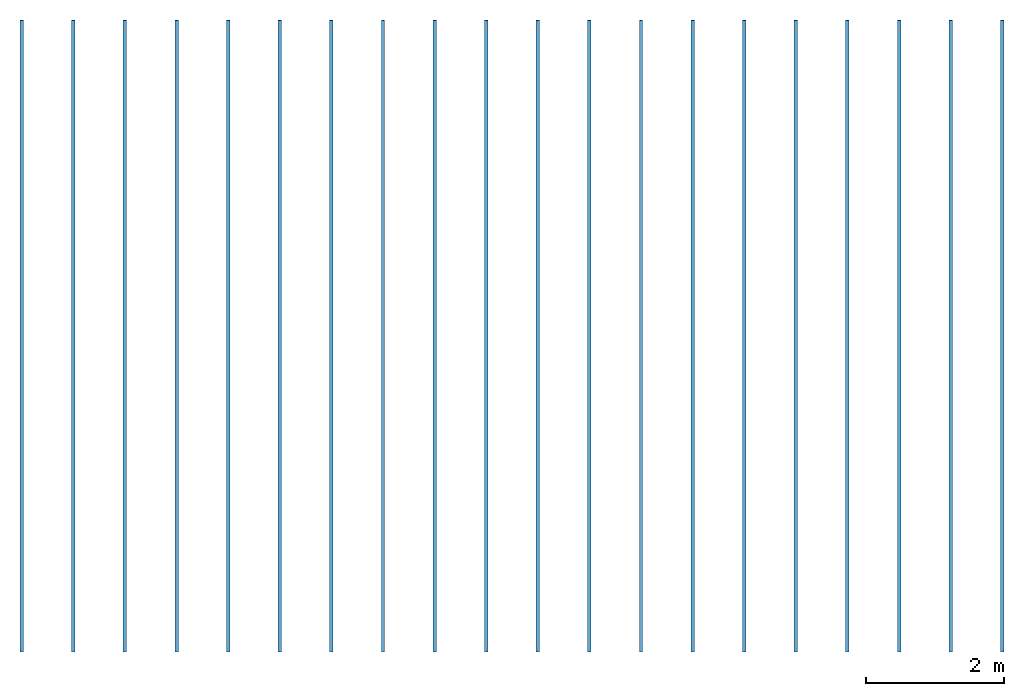
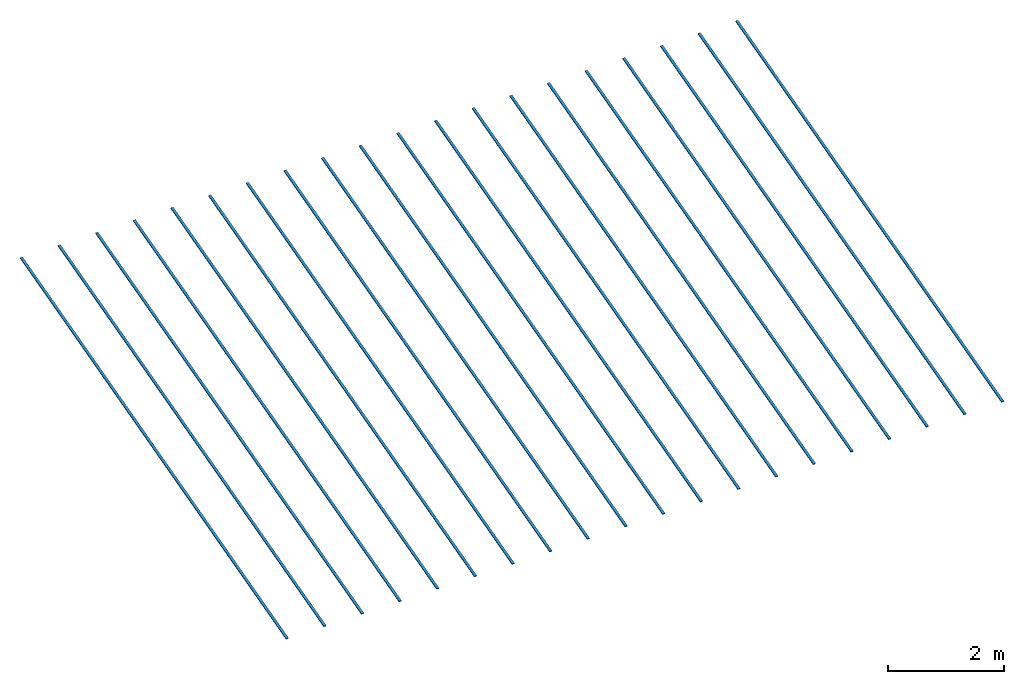
# Not in any storey: 20 beams.
"""IFC4 model written with IfcOpenShell, lengths in metres."""

from ifc_helpers import new_model, entity, si_unit, converted_unit, frame, origin_with_axes, origin_2d_with_axis, place, context, subcontext, project, rectangle, extrude, material, material_profile, profile_set, profile_usage, type_object, element, save


model = new_model("IFC4")

# Units and contexts
model_context = context("Model", 3, precision=1e-05, world=origin_with_axes())
plan_context = context("Plan", 2, precision=1e-05, world=origin_2d_with_axis())
body_context = subcontext(model_context, "Body", "Model", "MODEL_VIEW")
ifc_project = project(units=[si_unit("VOLUMEUNIT", "CUBIC_METRE"), si_unit("LENGTHUNIT", "METRE"), converted_unit("PLANEANGLEUNIT", "degree", entity("IfcReal", 0.0174532925199433), si_unit("PLANEANGLEUNIT", "RADIAN"), dimensions=[0, 0, 0, 0, 0, 0, 0]), si_unit("AREAUNIT", "SQUARE_METRE")], contexts=[model_context, plan_context])

# Beams
ifc_material = material()
ifc_material_profile = material_profile(ifc_material, rectangle(XDim=0.0500000007450581, YDim=0.0199999995529652))
ifc_profile_set = profile_set([ifc_material_profile])
ifc_profile_usage_1 = profile_usage(ifc_profile_set, cardinal=2)
beam_type = type_object("IfcBeamType", PredefinedType="BEAM", material=ifc_profile_set)
beam_1_placement = place(None, frame((-0.685000061988831, -1.53888702392578, 3.95000076293945), z_axis=(-1.05647404780029e-06, 0.965925574302673, 0.258819997310638), x_axis=(-1.0, -1.10467010472348e-06, 4.078152215925e-08)))
element("IfcBeam", 1, at=beam_1_placement, type_object=beam_type, material=ifc_profile_usage_1, Name="Beam", PredefinedType="NOTDEFINED", context=body_context, shape_type="SweptSolid", body=[
    extrude(rectangle(XDim=0.0500000007450581, YDim=0.0199999995529652), frame((0.0, 0.0099999997764826, 0.0), z_axis=(0.0, 0.0, 1.0), x_axis=(1.0, 0.0, 0.0)), (0.0, 0.0, 1.0), 9.49992295284267),
])
ifc_profile_usage_2 = profile_usage(ifc_profile_set, cardinal=2)
beam_2_placement = place(None, frame((0.0649999380111694, -1.53888702392578, 3.95000076293945), z_axis=(-1.05647404780029e-06, 0.965925574302673, 0.258819997310638), x_axis=(-1.0, -1.10467010472348e-06, 4.078152215925e-08)))
element("IfcBeam", 2, at=beam_2_placement, type_object=beam_type, material=ifc_profile_usage_2, Name="Beam", PredefinedType="NOTDEFINED", context=body_context, shape_type="SweptSolid", body=[
    extrude(rectangle(XDim=0.0500000007450581, YDim=0.0199999995529652), frame((0.0, 0.0099999997764826, 0.0), z_axis=(0.0, 0.0, 1.0), x_axis=(1.0, 0.0, 0.0)), (0.0, 0.0, 1.0), 9.49992295284267),
])
ifc_profile_usage_3 = profile_usage(ifc_profile_set, cardinal=2)
beam_3_placement = place(None, frame((0.814999938011169, -1.53888702392578, 3.95000076293945), z_axis=(-1.05647404780029e-06, 0.965925574302673, 0.258819997310638), x_axis=(-1.0, -1.10467010472348e-06, 4.078152215925e-08)))
element("IfcBeam", 3, at=beam_3_placement, type_object=beam_type, material=ifc_profile_usage_3, Name="Beam", PredefinedType="NOTDEFINED", context=body_context, shape_type="SweptSolid", body=[
    extrude(rectangle(XDim=0.0500000007450581, YDim=0.0199999995529652), frame((0.0, 0.0099999997764826, 0.0), z_axis=(0.0, 0.0, 1.0), x_axis=(1.0, 0.0, 0.0)), (0.0, 0.0, 1.0), 9.49992295284267),
])
ifc_profile_usage_4 = profile_usage(ifc_profile_set, cardinal=2)
beam_4_placement = place(None, frame((1.56499993801117, -1.53888702392578, 3.95000076293945), z_axis=(-1.05647404780029e-06, 0.965925574302673, 0.258819997310638), x_axis=(-1.0, -1.10467010472348e-06, 4.078152215925e-08)))
element("IfcBeam", 4, at=beam_4_placement, type_object=beam_type, material=ifc_profile_usage_4, Name="Beam", PredefinedType="NOTDEFINED", context=body_context, shape_type="SweptSolid", body=[
    extrude(rectangle(XDim=0.0500000007450581, YDim=0.0199999995529652), frame((0.0, 0.0099999997764826, 0.0), z_axis=(0.0, 0.0, 1.0), x_axis=(1.0, 0.0, 0.0)), (0.0, 0.0, 1.0), 9.49992295284267),
])
ifc_profile_usage_5 = profile_usage(ifc_profile_set, cardinal=2)
beam_5_placement = place(None, frame((2.31500005722046, -1.53888702392578, 3.95000076293945), z_axis=(-1.05647404780029e-06, 0.965925574302673, 0.258819997310638), x_axis=(-1.0, -1.10467010472348e-06, 4.078152215925e-08)))
element("IfcBeam", 5, at=beam_5_placement, type_object=beam_type, material=ifc_profile_usage_5, Name="Beam", PredefinedType="NOTDEFINED", context=body_context, shape_type="SweptSolid", body=[
    extrude(rectangle(XDim=0.0500000007450581, YDim=0.0199999995529652), frame((0.0, 0.0099999997764826, 0.0), z_axis=(0.0, 0.0, 1.0), x_axis=(1.0, 0.0, 0.0)), (0.0, 0.0, 1.0), 9.49992295284267),
])
ifc_profile_usage_6 = profile_usage(ifc_profile_set, cardinal=2)
beam_6_placement = place(None, frame((3.06500005722046, -1.53888702392578, 3.95000076293945), z_axis=(-1.05647404780029e-06, 0.965925574302673, 0.258819997310638), x_axis=(-1.0, -1.10467010472348e-06, 4.078152215925e-08)))
element("IfcBeam", 6, at=beam_6_placement, type_object=beam_type, material=ifc_profile_usage_6, Name="Beam", PredefinedType="NOTDEFINED", context=body_context, shape_type="SweptSolid", body=[
    extrude(rectangle(XDim=0.0500000007450581, YDim=0.0199999995529652), frame((0.0, 0.0099999997764826, 0.0), z_axis=(0.0, 0.0, 1.0), x_axis=(1.0, 0.0, 0.0)), (0.0, 0.0, 1.0), 9.49992295284267),
])
ifc_profile_usage_7 = profile_usage(ifc_profile_set, cardinal=2)
beam_7_placement = place(None, frame((3.81500005722046, -1.53888702392578, 3.95000076293945), z_axis=(-1.05647404780029e-06, 0.965925574302673, 0.258819997310638), x_axis=(-1.0, -1.10467010472348e-06, 4.078152215925e-08)))
element("IfcBeam", 7, at=beam_7_placement, type_object=beam_type, material=ifc_profile_usage_7, Name="Beam", PredefinedType="NOTDEFINED", context=body_context, shape_type="SweptSolid", body=[
    extrude(rectangle(XDim=0.0500000007450581, YDim=0.0199999995529652), frame((0.0, 0.0099999997764826, 0.0), z_axis=(0.0, 0.0, 1.0), x_axis=(1.0, 0.0, 0.0)), (0.0, 0.0, 1.0), 9.49992295284267),
])
ifc_profile_usage_8 = profile_usage(ifc_profile_set, cardinal=2)
beam_8_placement = place(None, frame((4.56500005722046, -1.53888702392578, 3.95000076293945), z_axis=(-1.05647404780029e-06, 0.965925574302673, 0.258819997310638), x_axis=(-1.0, -1.10467010472348e-06, 4.078152215925e-08)))
element("IfcBeam", 8, at=beam_8_placement, type_object=beam_type, material=ifc_profile_usage_8, Name="Beam", PredefinedType="NOTDEFINED", context=body_context, shape_type="SweptSolid", body=[
    extrude(rectangle(XDim=0.0500000007450581, YDim=0.0199999995529652), frame((0.0, 0.0099999997764826, 0.0), z_axis=(0.0, 0.0, 1.0), x_axis=(1.0, 0.0, 0.0)), (0.0, 0.0, 1.0), 9.49992295284267),
])
ifc_profile_usage_9 = profile_usage(ifc_profile_set, cardinal=2)
beam_9_placement = place(None, frame((5.31500005722046, -1.53888702392578, 3.95000076293945), z_axis=(-1.05647404780029e-06, 0.965925574302673, 0.258819997310638), x_axis=(-1.0, -1.10467010472348e-06, 4.078152215925e-08)))
element("IfcBeam", 9, at=beam_9_placement, type_object=beam_type, material=ifc_profile_usage_9, Name="Beam", PredefinedType="NOTDEFINED", context=body_context, shape_type="SweptSolid", body=[
    extrude(rectangle(XDim=0.0500000007450581, YDim=0.0199999995529652), frame((0.0, 0.0099999997764826, 0.0), z_axis=(0.0, 0.0, 1.0), x_axis=(1.0, 0.0, 0.0)), (0.0, 0.0, 1.0), 9.49992295284267),
])
ifc_profile_usage_10 = profile_usage(ifc_profile_set, cardinal=2)
beam_10_placement = place(None, frame((6.06500005722046, -1.53888702392578, 3.95000076293945), z_axis=(-1.05647404780029e-06, 0.965925574302673, 0.258819997310638), x_axis=(-1.0, -1.10467010472348e-06, 4.078152215925e-08)))
element("IfcBeam", 10, at=beam_10_placement, type_object=beam_type, material=ifc_profile_usage_10, Name="Beam", PredefinedType="NOTDEFINED", context=body_context, shape_type="SweptSolid", body=[
    extrude(rectangle(XDim=0.0500000007450581, YDim=0.0199999995529652), frame((0.0, 0.0099999997764826, 0.0), z_axis=(0.0, 0.0, 1.0), x_axis=(1.0, 0.0, 0.0)), (0.0, 0.0, 1.0), 9.49992295284267),
])
ifc_profile_usage_11 = profile_usage(ifc_profile_set, cardinal=2)
beam_11_placement = place(None, frame((6.81500005722046, -1.53888702392578, 3.95000076293945), z_axis=(-1.05647404780029e-06, 0.965925574302673, 0.258819997310638), x_axis=(-1.0, -1.10467010472348e-06, 4.078152215925e-08)))
element("IfcBeam", 11, at=beam_11_placement, type_object=beam_type, material=ifc_profile_usage_11, Name="Beam", PredefinedType="NOTDEFINED", context=body_context, shape_type="SweptSolid", body=[
    extrude(rectangle(XDim=0.0500000007450581, YDim=0.0199999995529652), frame((0.0, 0.0099999997764826, 0.0), z_axis=(0.0, 0.0, 1.0), x_axis=(1.0, 0.0, 0.0)), (0.0, 0.0, 1.0), 9.49992295284267),
])
ifc_profile_usage_12 = profile_usage(ifc_profile_set, cardinal=2)
beam_12_placement = place(None, frame((7.56500005722046, -1.53888702392578, 3.95000076293945), z_axis=(-1.05647404780029e-06, 0.965925574302673, 0.258819997310638), x_axis=(-1.0, -1.10467010472348e-06, 4.078152215925e-08)))
element("IfcBeam", 12, at=beam_12_placement, type_object=beam_type, material=ifc_profile_usage_12, Name="Beam", PredefinedType="NOTDEFINED", context=body_context, shape_type="SweptSolid", body=[
    extrude(rectangle(XDim=0.0500000007450581, YDim=0.0199999995529652), frame((0.0, 0.0099999997764826, 0.0), z_axis=(0.0, 0.0, 1.0), x_axis=(1.0, 0.0, 0.0)), (0.0, 0.0, 1.0), 9.49992295284267),
])
ifc_profile_usage_13 = profile_usage(ifc_profile_set, cardinal=2)
beam_13_placement = place(None, frame((8.3149995803833, -1.53888702392578, 3.95000076293945), z_axis=(-1.05647404780029e-06, 0.965925574302673, 0.258819997310638), x_axis=(-1.0, -1.10467010472348e-06, 4.078152215925e-08)))
element("IfcBeam", 13, at=beam_13_placement, type_object=beam_type, material=ifc_profile_usage_13, Name="Beam", PredefinedType="NOTDEFINED", context=body_context, shape_type="SweptSolid", body=[
    extrude(rectangle(XDim=0.0500000007450581, YDim=0.0199999995529652), frame((0.0, 0.0099999997764826, 0.0), z_axis=(0.0, 0.0, 1.0), x_axis=(1.0, 0.0, 0.0)), (0.0, 0.0, 1.0), 9.49992295284267),
])
ifc_profile_usage_14 = profile_usage(ifc_profile_set, cardinal=2)
beam_14_placement = place(None, frame((9.0649995803833, -1.53888702392578, 3.95000076293945), z_axis=(-1.05647404780029e-06, 0.965925574302673, 0.258819997310638), x_axis=(-1.0, -1.10467010472348e-06, 4.078152215925e-08)))
element("IfcBeam", 14, at=beam_14_placement, type_object=beam_type, material=ifc_profile_usage_14, Name="Beam", PredefinedType="NOTDEFINED", context=body_context, shape_type="SweptSolid", body=[
    extrude(rectangle(XDim=0.0500000007450581, YDim=0.0199999995529652), frame((0.0, 0.0099999997764826, 0.0), z_axis=(0.0, 0.0, 1.0), x_axis=(1.0, 0.0, 0.0)), (0.0, 0.0, 1.0), 9.49992295284267),
])
ifc_profile_usage_15 = profile_usage(ifc_profile_set, cardinal=2)
beam_15_placement = place(None, frame((9.8149995803833, -1.53888702392578, 3.95000076293945), z_axis=(-1.05647404780029e-06, 0.965925574302673, 0.258819997310638), x_axis=(-1.0, -1.10467010472348e-06, 4.078152215925e-08)))
element("IfcBeam", 15, at=beam_15_placement, type_object=beam_type, material=ifc_profile_usage_15, Name="Beam", PredefinedType="NOTDEFINED", context=body_context, shape_type="SweptSolid", body=[
    extrude(rectangle(XDim=0.0500000007450581, YDim=0.0199999995529652), frame((0.0, 0.0099999997764826, 0.0), z_axis=(0.0, 0.0, 1.0), x_axis=(1.0, 0.0, 0.0)), (0.0, 0.0, 1.0), 9.49992295284267),
])
ifc_profile_usage_16 = profile_usage(ifc_profile_set, cardinal=2)
beam_16_placement = place(None, frame((10.5649995803833, -1.53888702392578, 3.95000076293945), z_axis=(-1.05647404780029e-06, 0.965925574302673, 0.258819997310638), x_axis=(-1.0, -1.10467010472348e-06, 4.078152215925e-08)))
element("IfcBeam", 16, at=beam_16_placement, type_object=beam_type, material=ifc_profile_usage_16, Name="Beam", PredefinedType="NOTDEFINED", context=body_context, shape_type="SweptSolid", body=[
    extrude(rectangle(XDim=0.0500000007450581, YDim=0.0199999995529652), frame((0.0, 0.0099999997764826, 0.0), z_axis=(0.0, 0.0, 1.0), x_axis=(1.0, 0.0, 0.0)), (0.0, 0.0, 1.0), 9.49992295284267),
])
ifc_profile_usage_17 = profile_usage(ifc_profile_set, cardinal=2)
beam_17_placement = place(None, frame((11.3149995803833, -1.53888702392578, 3.95000076293945), z_axis=(-1.05647404780029e-06, 0.965925574302673, 0.258819997310638), x_axis=(-1.0, -1.10467010472348e-06, 4.078152215925e-08)))
element("IfcBeam", 17, at=beam_17_placement, type_object=beam_type, material=ifc_profile_usage_17, Name="Beam", PredefinedType="NOTDEFINED", context=body_context, shape_type="SweptSolid", body=[
    extrude(rectangle(XDim=0.0500000007450581, YDim=0.0199999995529652), frame((0.0, 0.0099999997764826, 0.0), z_axis=(0.0, 0.0, 1.0), x_axis=(1.0, 0.0, 0.0)), (0.0, 0.0, 1.0), 9.49992295284267),
])
ifc_profile_usage_18 = profile_usage(ifc_profile_set, cardinal=2)
beam_18_placement = place(None, frame((12.0649995803833, -1.53888702392578, 3.95000076293945), z_axis=(-1.05647404780029e-06, 0.965925574302673, 0.258819997310638), x_axis=(-1.0, -1.10467010472348e-06, 4.078152215925e-08)))
element("IfcBeam", 18, at=beam_18_placement, type_object=beam_type, material=ifc_profile_usage_18, Name="Beam", PredefinedType="NOTDEFINED", context=body_context, shape_type="SweptSolid", body=[
    extrude(rectangle(XDim=0.0500000007450581, YDim=0.0199999995529652), frame((0.0, 0.0099999997764826, 0.0), z_axis=(0.0, 0.0, 1.0), x_axis=(1.0, 0.0, 0.0)), (0.0, 0.0, 1.0), 9.49992295284267),
])
ifc_profile_usage_19 = profile_usage(ifc_profile_set, cardinal=2)
beam_19_placement = place(None, frame((12.8149995803833, -1.53888702392578, 3.95000076293945), z_axis=(-1.05647404780029e-06, 0.965925574302673, 0.258819997310638), x_axis=(-1.0, -1.10467010472348e-06, 4.078152215925e-08)))
element("IfcBeam", 19, at=beam_19_placement, type_object=beam_type, material=ifc_profile_usage_19, Name="Beam", PredefinedType="NOTDEFINED", context=body_context, shape_type="SweptSolid", body=[
    extrude(rectangle(XDim=0.0500000007450581, YDim=0.0199999995529652), frame((0.0, 0.0099999997764826, 0.0), z_axis=(0.0, 0.0, 1.0), x_axis=(1.0, 0.0, 0.0)), (0.0, 0.0, 1.0), 9.49992295284267),
])
ifc_profile_usage_20 = profile_usage(ifc_profile_set, cardinal=2)
beam_20_placement = place(None, frame((13.5649995803833, -1.53888702392578, 3.95000076293945), z_axis=(-1.05647404780029e-06, 0.965925574302673, 0.258819997310638), x_axis=(-1.0, -1.10467010472348e-06, 4.078152215925e-08)))
element("IfcBeam", 20, at=beam_20_placement, type_object=beam_type, material=ifc_profile_usage_20, Name="Beam", PredefinedType="NOTDEFINED", context=body_context, shape_type="SweptSolid", body=[
    extrude(rectangle(XDim=0.0500000007450581, YDim=0.0199999995529652), frame((0.0, 0.0099999997764826, 0.0), z_axis=(0.0, 0.0, 1.0), x_axis=(1.0, 0.0, 0.0)), (0.0, 0.0, 1.0), 9.49992295284267),
])

save(model, "model.ifc")
